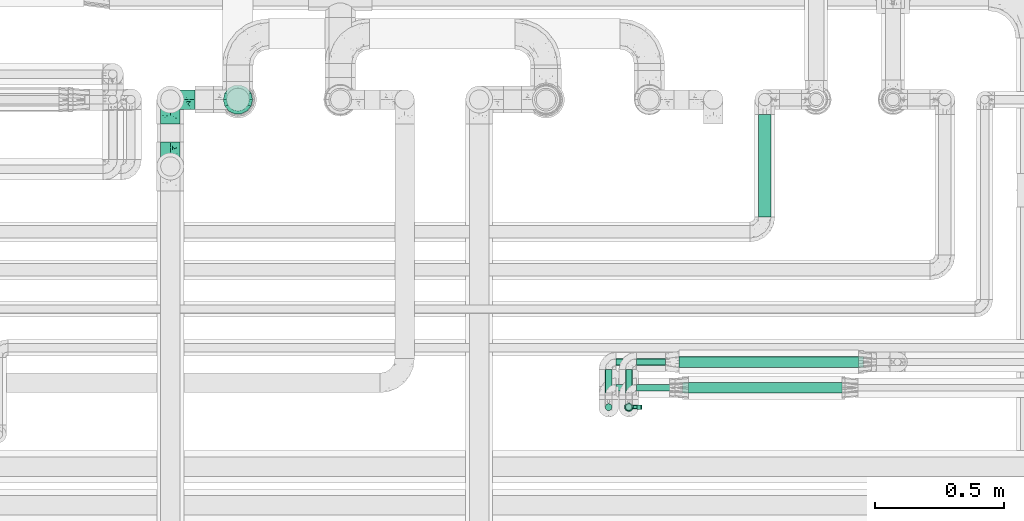
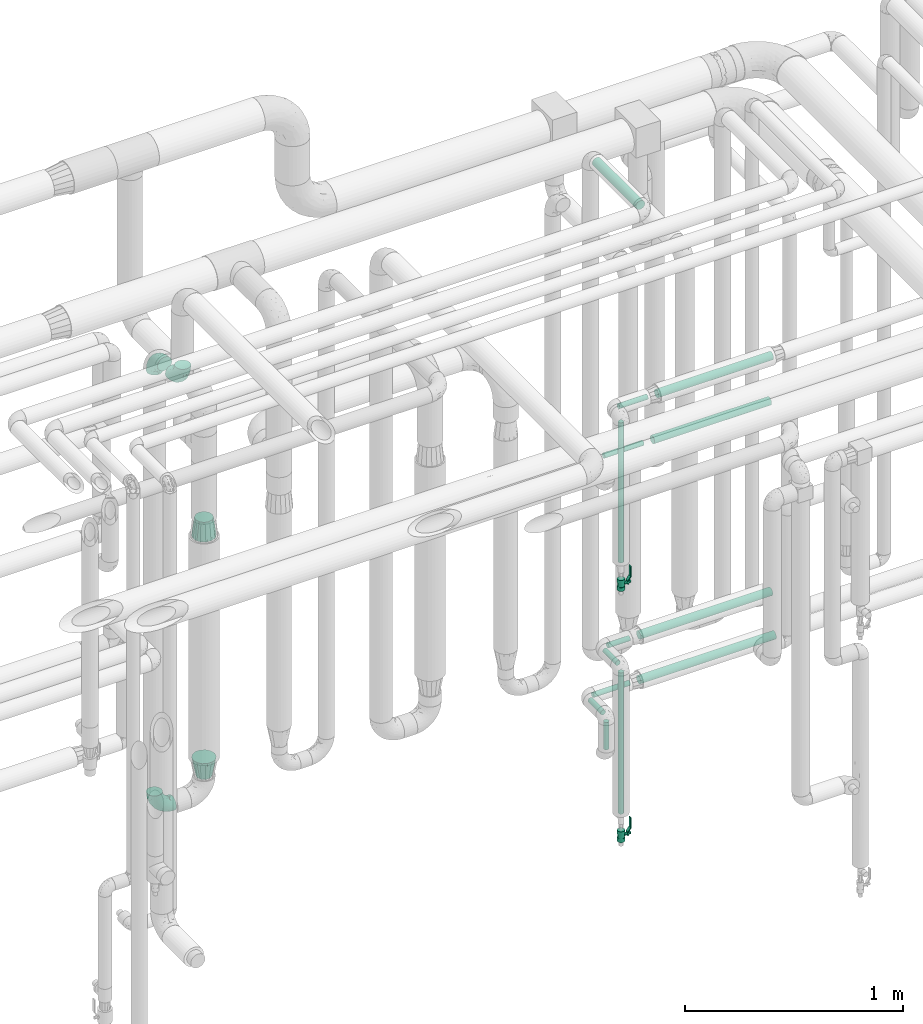
# One storey, part 709 of 827: 14 flow segments, 5 flow fittings, 2 flow controllers.
"""IFC2X3 building model written with IfcOpenShell, lengths in millimetres."""

from ifc_helpers import new_model, entity, si_unit, converted_unit, derived_unit, direction, frame, origin, origin_2d_with_axis, place, context, subcontext, project, spatial, polyline, circle, outline, extrude, faceted_brep, source, transform, mapped, material, material_list, type_object, type_shapes, element, save


model = new_model("IFC2X3")

# Units and contexts
model_context = context("Model", 3, precision=0.01, world=origin(), true_north=direction((6.12303176911189e-17, 1.0)))
body_context = subcontext(model_context, "Body", "Model", "MODEL_VIEW")
ifc_project = project(units=[si_unit("LENGTHUNIT", "METRE", prefix="MILLI"), si_unit("AREAUNIT", "SQUARE_METRE"), si_unit("VOLUMEUNIT", "CUBIC_METRE"), converted_unit("PLANEANGLEUNIT", "DEGREE", entity("IfcRatioMeasure", 0.0174532925199433), si_unit("PLANEANGLEUNIT", "RADIAN"), dimensions=[0, 0, 0, 0, 0, 0, 0]), si_unit("MASSUNIT", "GRAM", prefix="KILO"), derived_unit("MASSDENSITYUNIT", [(si_unit("MASSUNIT", "GRAM", prefix="KILO"), 1), (si_unit("LENGTHUNIT", "METRE"), -3)]), derived_unit("MOMENTOFINERTIAUNIT", [(si_unit("LENGTHUNIT", "METRE"), 4)]), si_unit("TIMEUNIT", "SECOND"), si_unit("FREQUENCYUNIT", "HERTZ"), si_unit("THERMODYNAMICTEMPERATUREUNIT", "DEGREE_CELSIUS"), derived_unit("THERMALTRANSMITTANCEUNIT", [(si_unit("MASSUNIT", "GRAM", prefix="KILO"), 1), (si_unit("THERMODYNAMICTEMPERATUREUNIT", "KELVIN"), -1), (si_unit("TIMEUNIT", "SECOND"), -3)]), derived_unit("VOLUMETRICFLOWRATEUNIT", [(si_unit("LENGTHUNIT", "METRE"), 3), (si_unit("TIMEUNIT", "SECOND"), -1)]), derived_unit("MASSFLOWRATEUNIT", [(si_unit("MASSUNIT", "GRAM", prefix="KILO"), 1), (si_unit("TIMEUNIT", "SECOND"), -1)]), derived_unit("ROTATIONALFREQUENCYUNIT", [(si_unit("TIMEUNIT", "SECOND"), -1)]), si_unit("ELECTRICCURRENTUNIT", "AMPERE"), si_unit("ELECTRICVOLTAGEUNIT", "VOLT"), si_unit("POWERUNIT", "WATT"), si_unit("FORCEUNIT", "NEWTON", prefix="KILO"), si_unit("ILLUMINANCEUNIT", "LUX"), si_unit("LUMINOUSFLUXUNIT", "LUMEN"), si_unit("LUMINOUSINTENSITYUNIT", "CANDELA"), derived_unit("USERDEFINED", [(si_unit("MASSUNIT", "GRAM", prefix="KILO"), -1), (si_unit("LENGTHUNIT", "METRE"), -2), (si_unit("TIMEUNIT", "SECOND"), 3), (si_unit("LUMINOUSFLUXUNIT", "LUMEN"), 1)]), derived_unit("LINEARVELOCITYUNIT", [(si_unit("LENGTHUNIT", "METRE"), 1), (si_unit("TIMEUNIT", "SECOND"), -1)]), si_unit("PRESSUREUNIT", "PASCAL"), derived_unit("USERDEFINED", [(si_unit("LENGTHUNIT", "METRE"), -2), (si_unit("MASSUNIT", "GRAM", prefix="KILO"), 1), (si_unit("TIMEUNIT", "SECOND"), -2)]), derived_unit("LINEARFORCEUNIT", [(si_unit("MASSUNIT", "GRAM", prefix="KILO"), 1), (si_unit("LENGTHUNIT", "METRE"), 1), (si_unit("TIMEUNIT", "SECOND"), -2), (si_unit("LENGTHUNIT", "METRE"), -1)]), derived_unit("PLANARFORCEUNIT", [(si_unit("MASSUNIT", "GRAM", prefix="KILO"), 1), (si_unit("LENGTHUNIT", "METRE"), 1), (si_unit("TIMEUNIT", "SECOND"), -2), (si_unit("LENGTHUNIT", "METRE"), -2)])], contexts=[model_context])

# Site, building, storey
site_placement = place(None, origin())
site = spatial("IfcSite", under=ifc_project, at=site_placement, CompositionType="ELEMENT")
building_placement = place(site_placement, origin())
building = spatial("IfcBuilding", under=site, at=building_placement, CompositionType="ELEMENT")
storey_placement = place(building_placement, frame((0.0, 0.0, 28200.0)))
storey = spatial("IfcBuildingStorey", under=building, at=storey_placement, Name="08", CompositionType="ELEMENT", Elevation=28200.0)

# Flow segments
pipe_segment_type = type_object("IfcPipeSegmentType", PredefinedType="NOTDEFINED")
flow_segment_1_placement = place(storey_placement, frame((58598.69, 16364.84, 2635.0)))
element("IfcFlowSegment", 1, at=flow_segment_1_placement, inside=storey, type_object=pipe_segment_type, context=body_context, shape_type="SweptSolid", body=[
    extrude(circle(Radius=13.4, at=origin_2d_with_axis()), frame((0.0, 15.0, 15.0), z_axis=(1.0, 0.0, 0.0), x_axis=(0.0, 1.0, 0.0)), (0.0, 0.0, 1.0), 151.411857725938),
])
flow_segment_2_placement = place(storey_placement, frame((58554.6, 16289.84, 1836.7)))
element("IfcFlowSegment", 2, at=flow_segment_2_placement, inside=storey, type_object=pipe_segment_type, context=body_context, shape_type="SweptSolid", body=[
    extrude(circle(Radius=13.4, at=origin_2d_with_axis()), frame((15.0, 15.0, 0.0)), (0.0, 0.0, 1.0), 784.200205145647),
])
flow_segment_3_placement = place(storey_placement, frame((58554.6, 16333.95, 1235.0)))
element("IfcFlowSegment", 3, at=flow_segment_3_placement, inside=storey, type_object=pipe_segment_type, context=body_context, shape_type="SweptSolid", body=[
    extrude(circle(Radius=13.4, at=origin_2d_with_axis()), frame((15.0, 0.0, 15.0), z_axis=(0.0, 1.0, 0.0), x_axis=(1.0, 0.0, 0.0)), (0.0, 0.0, 1.0), 116.174999999997),
])
flow_segment_4_placement = place(storey_placement, frame((58554.6, 16289.85, 429.0)))
element("IfcFlowSegment", 4, at=flow_segment_4_placement, inside=storey, type_object=pipe_segment_type, context=body_context, shape_type="SweptSolid", body=[
    extrude(circle(Radius=13.4, at=origin_2d_with_axis()), frame((15.0, 15.0, 0.0)), (0.0, 0.0, 1.0), 791.899999709113),
])
flow_segment_5_placement = place(storey_placement, frame((58598.69, 16464.23, 1235.0)))
element("IfcFlowSegment", 5, at=flow_segment_5_placement, inside=storey, type_object=pipe_segment_type, context=body_context, shape_type="SweptSolid", body=[
    extrude(circle(Radius=13.4, at=origin_2d_with_axis()), frame((0.0, 15.0, 15.0), z_axis=(1.0, 0.0, 0.0), x_axis=(0.0, -1.0, 0.0)), (0.0, 0.0, 1.0), 114.325940465235),
])
flow_segment_6_placement = place(storey_placement, frame((58476.2, 16333.49, 985.0)))
element("IfcFlowSegment", 6, at=flow_segment_6_placement, inside=storey, type_object=pipe_segment_type, context=body_context, shape_type="SweptSolid", body=[
    extrude(circle(Radius=13.4, at=origin_2d_with_axis()), frame((15.0, 0.0, 15.0), z_axis=(0.0, 1.0, 0.0), x_axis=(1.0, 0.0, 0.0)), (0.0, 0.0, 1.0), 116.636658406557),
])
flow_segment_7_placement = place(storey_placement, frame((58476.2, 16289.39, 817.55)))
element("IfcFlowSegment", 7, at=flow_segment_7_placement, inside=storey, type_object=pipe_segment_type, context=body_context, shape_type="SweptSolid", body=[
    extrude(circle(Radius=13.4, at=origin_2d_with_axis()), frame((15.0, 15.0, 0.0)), (0.0, 0.0, 1.0), 153.34576210052),
])
flow_segment_8_placement = place(storey_placement, frame((58520.29, 16464.19, 985.0)))
element("IfcFlowSegment", 8, at=flow_segment_8_placement, inside=storey, type_object=pipe_segment_type, context=body_context, shape_type="SweptSolid", body=[
    extrude(circle(Radius=13.4, at=origin_2d_with_axis()), frame((0.0, 15.03, 15.0), z_axis=(0.999999985627903, -0.000169541125269406, 0.0), x_axis=(-0.000169541125269406, -0.999999985627903, 0.0)), (0.0, 0.0, 1.0), 192.725953702304),
])
flow_segment_9_placement = place(storey_placement, frame((59072.54, 17042.69, 3174.4)))
element("IfcFlowSegment", 9, at=flow_segment_9_placement, inside=storey, type_object=pipe_segment_type, context=body_context, shape_type="SweptSolid", body=[
    extrude(circle(Radius=24.0, at=origin_2d_with_axis()), frame((25.6, 0.0, 25.6), z_axis=(0.0, 1.0, 0.0), x_axis=(-1.0, 0.0, 0.0)), (0.0, 0.0, 1.0), 400.304686356029),
])
flow_segment_10_placement = place(storey_placement, frame((58764.02, 16456.48, 977.25)))
element("IfcFlowSegment", 10, at=flow_segment_10_placement, inside=storey, type_object=pipe_segment_type, context=body_context, shape_type="SweptSolid", body=[
    extrude(circle(Radius=21.15, at=origin_2d_with_axis()), frame((0.0, 22.75, 22.75), z_axis=(1.0, 0.0, 6.7602214637812e-06), x_axis=(0.0, 1.0, 0.0)), (0.0, 0.0, 1.0), 717.619049674226),
])
flow_segment_11_placement = place(storey_placement, frame((58764.02, 16456.91, 1227.25)))
element("IfcFlowSegment", 11, at=flow_segment_11_placement, inside=storey, type_object=pipe_segment_type, context=body_context, shape_type="SweptSolid", body=[
    extrude(circle(Radius=21.15, at=origin_2d_with_axis()), frame((0.0, 22.75, 22.75), z_axis=(1.0, 0.0, 0.0), x_axis=(0.0, -1.0, 0.0)), (0.0, 0.0, 1.0), 698.842962557812),
])
flow_segment_12_placement = place(storey_placement, frame((58778.82, 16357.09, 2377.25)))
element("IfcFlowSegment", 12, at=flow_segment_12_placement, inside=storey, type_object=pipe_segment_type, context=body_context, shape_type="SweptSolid", body=[
    extrude(circle(Radius=21.15, at=origin_2d_with_axis()), frame((0.0, 22.75, 22.75), z_axis=(1.0, 0.0, 0.0), x_axis=(0.0, 1.0, 0.0)), (0.0, 0.0, 1.0), 620.000000000006),
])
flow_segment_13_placement = place(storey_placement, frame((58801.1, 16357.09, 2627.25)))
element("IfcFlowSegment", 13, at=flow_segment_13_placement, inside=storey, type_object=pipe_segment_type, context=body_context, shape_type="SweptSolid", body=[
    extrude(circle(Radius=21.15, at=origin_2d_with_axis()), frame((0.0, 22.75, 22.75), z_axis=(1.0, 0.0, 0.0), x_axis=(0.0, -1.0, 0.0)), (0.0, 0.0, 1.0), 608.330451835312),
])
flow_segment_14_placement = place(storey_placement, frame((58520.29, 16364.84, 2385.0)))
element("IfcFlowSegment", 14, at=flow_segment_14_placement, inside=storey, type_object=pipe_segment_type, context=body_context, shape_type="SweptSolid", body=[
    extrude(circle(Radius=13.4, at=origin_2d_with_axis()), frame((0.0, 15.0, 15.0), z_axis=(1.0, 0.0, 0.0), x_axis=(0.0, 1.0, 0.0)), (0.0, 0.0, 1.0), 207.529319801584),
])

# Flow controllers
ifc_material = material()
ifc_material_list = material_list([ifc_material, ifc_material, ifc_material, ifc_material, ifc_material])
valve_type = type_object("IfcValveType", PredefinedType="NOTDEFINED", material=ifc_material_list)
shared_shape_1 = source(origin(), body_context, "Body", "SweptSolid", [
    extrude(circle(Radius=17.5, at=origin_2d_with_axis()), frame((-30.5, 0.0, 0.0), z_axis=(1.0, 0.0, 0.0), x_axis=(0.0, 1.0, 0.0)), (0.0, 0.0, 1.0), 20.3333333333333),
    extrude(circle(Radius=16.0, at=origin_2d_with_axis()), frame((-10.17, 0.0, 0.0), z_axis=(1.0, 0.0, 0.0), x_axis=(0.0, 1.0, 0.0)), (0.0, 0.0, 1.0), 20.3333333333333),
    extrude(circle(Radius=17.5, at=origin_2d_with_axis()), frame((10.17, 0.0, 0.0), z_axis=(1.0, 0.0, 0.0), x_axis=(0.0, 1.0, 0.0)), (0.0, 0.0, 1.0), 20.3333333333333),
    extrude(outline(polyline([(-38.75, -5.0), (-38.75, -10.0), (-17.92, -10.0), (2.08, 5.0), (56.25, 5.0), (56.25, 10.0), (0.42, 10.0), (-19.58, -5.0), (-38.75, -5.0)])), frame((28.75, -8.75, 41.5), z_axis=(0.0, -1.0, 0.0), x_axis=(1.0, 0.0, 0.0)), (0.0, 0.0, -1.0), 17.5),
    extrude(circle(Radius=8.0, at=origin_2d_with_axis()), origin(), (0.0, 0.0, 1.0), 49.0),
])
type_shapes(valve_type, [shared_shape_1])
for number, where, z_axis, x_axis in (
    (15, (58569.59, 16304.84, 1710.2), (1.0, 0.0, 0.0), (0.0, 0.0, 1.0)),
    (16, (58569.59, 16304.85, 302.5), (1.0, 0.0, 0.0), (0.0, 0.0, 1.0)),
):
    element("IfcFlowController", number, at=place(storey_placement, frame(where, z_axis=z_axis, x_axis=x_axis)), inside=storey, type_object=valve_type, material=ifc_material, context=body_context, shape_type="MappedRepresentation", body=[
        mapped(shared_shape_1, transform((0.0, 0.0, 0.0), scale=1.0)),
    ])

# Flow fittings
pipe_fitting_type_1 = type_object("IfcPipeFittingType", Name="ADSK_1", PredefinedType="NOTDEFINED", material=ifc_material)
shared_shape_2 = source(origin(), body_context, "Body", "Brep", [
    faceted_brep([(-95.0, 19.02, -32.95), (-95.0, 9.85, -36.75), (-95.0, 0.0, -38.05), (-95.0, -9.85, -36.75), (-95.0, -19.03, -32.95), (-95.0, -26.91, -26.91), (-95.0, -32.95, -19.03), (-95.0, -36.75, -9.85), (-95.0, -38.05, 0.0), (-95.0, -36.75, 9.85), (-95.0, -32.95, 19.02), (-95.0, -26.91, 26.91), (-95.0, -19.03, 32.95), (-95.0, -9.85, 36.75), (-95.0, 0.0, 38.05), (-95.0, 9.85, 36.75), (-95.0, 19.02, 32.95), (-95.0, 26.91, 26.91), (-95.0, 32.95, 19.02), (-95.0, 36.75, 9.85), (-95.0, 38.05, 0.0), (-95.0, 36.75, -9.85), (-95.0, 32.95, -19.03), (-95.0, 26.91, -26.91), (0.0, 95.0, -38.05), (-9.85, 95.0, -36.75), (-19.02, 95.0, -32.95), (-26.91, 95.0, -26.91), (-32.95, 95.0, -19.03), (-36.75, 95.0, -9.85), (-38.05, 95.0, 0.0), (-36.75, 95.0, 9.85), (-32.95, 95.0, 19.02), (-26.91, 95.0, 26.91), (-19.02, 95.0, 32.95), (-9.85, 95.0, 36.75), (0.0, 95.0, 38.05), (9.85, 95.0, 36.75), (19.03, 95.0, 32.95), (26.91, 95.0, 26.91), (32.95, 95.0, 19.02), (36.75, 95.0, 9.85), (38.05, 95.0, 0.0), (36.75, 95.0, -9.85), (32.95, 95.0, -19.03), (26.91, 95.0, -26.91), (19.03, 95.0, -32.95), (9.85, 95.0, -36.75), (-7.99, -4.96, 6.3), (-0.92, 0.92, 0.0), (4.62, 8.1, 8.01), (-76.19, -35.57, 0.0), (-64.32, -32.32, 12.43), (20.51, 62.45, 28.68), (-60.56, -33.52, 0.0), (-70.4, -13.47, 34.42), (-39.61, -5.88, 32.32), (-49.6, 2.07, 37.1), (-70.34, -28.81, 21.71), (14.64, 40.81, 26.5), (5.88, 39.61, 32.32), (3.59, 20.77, 25.31), (-40.45, 68.06, 16.75), (-62.45, -20.51, 28.68), (-44.52, -26.87, 0.0), (-28.47, -20.22, 0.0), (-26.43, -17.83, 8.75), (-76.1, 39.63, 10.76), (-72.74, 37.58, 18.19), (-60.35, 46.18, 14.61), (-13.4, 13.4, 32.12), (-20.77, -3.59, 25.31), (-14.66, 81.47, 35.56), (-6.22, 71.26, 37.92), (-57.5, 42.48, 22.79), (-15.0, 34.74, 37.7), (-27.1, 12.08, 36.05), (-9.2, 28.81, 35.63), (-79.98, 23.7, 30.95), (-73.68, -4.3, 37.48), (-30.74, 21.67, 37.97), (-62.36, 47.59, 6.79), (-72.71, 32.83, 24.69), (-67.42, 7.02, 37.95), (-32.13, 75.27, 24.51), (-43.46, 51.47, 26.26), (-24.98, 73.15, 31.29), (20.59, 41.28, 19.85), (7.79, 16.09, 15.86), (-73.21, 42.39, 0.0), (-54.73, 54.73, 0.0), (-73.44, 15.79, 35.79), (-5.94, 4.32, 20.43), (28.81, 70.34, 21.71), (32.32, 64.32, 12.43), (-53.59, 26.2, 35.09), (-52.02, 19.31, 37.21), (21.38, 33.53, 10.34), (26.87, 44.52, 0.0), (-48.28, 12.14, 38.05), (4.3, 73.68, 37.48), (-44.08, -25.52, 12.79), (-41.28, -20.59, 19.85), (35.57, 76.19, 0.0), (-47.26, 54.3, 20.18), (-47.4, 61.99, 8.58), (-42.39, 73.21, 0.0), (-39.67, 78.86, 7.21), (-45.69, 36.84, 33.11), (-32.83, 50.13, 33.35), (13.47, 70.4, 34.42), (-18.25, 63.73, 36.07), (-40.63, -13.75, 27.22), (-16.63, 46.37, 37.95), (-53.47, 38.79, 28.59), (-26.07, 48.54, 36.15), (-34.51, 34.51, 36.86), (-2.07, 49.6, 37.1), (-22.79, -10.49, 19.23), (-61.73, 28.67, 31.87), (9.65, 14.7, 0.0), (20.22, 28.47, 0.0), (33.52, 60.56, 0.0), (-11.42, -5.44, 13.25), (-14.7, -9.65, 0.0), (-81.47, 14.66, -35.56), (-62.45, -20.51, -28.68), (-71.26, 6.22, -37.92), (-75.27, 32.13, -24.51), (-73.15, 24.98, -31.29), (13.47, 70.4, -34.42), (5.88, 39.61, -32.32), (-2.07, 49.6, -37.1), (-78.86, 39.67, -7.21), (-70.4, -13.47, -34.42), (-39.61, -5.88, -32.32), (-61.99, 47.4, -8.58), (32.32, 64.32, -12.43), (28.81, 70.34, -21.71), (-63.73, 18.25, -36.07), (-50.13, 32.83, -33.35), (4.3, 73.68, -37.48), (-7.02, 67.42, -37.95), (-39.63, 76.1, -10.76), (-46.18, 60.35, -14.61), (-47.59, 62.36, -6.79), (-64.32, -32.32, -12.43), (-26.2, 53.59, -35.09), (-15.79, 73.44, -35.79), (-19.31, 52.02, -37.21), (-37.58, 72.74, -18.19), (-70.34, -28.81, -21.71), (-42.48, 57.5, -22.79), (-38.79, 53.47, -28.59), (-51.47, 43.46, -26.26), (-32.83, 72.71, -24.69), (-46.37, 16.63, -37.95), (-73.68, -4.3, -37.48), (-41.28, -20.59, -19.85), (-44.08, -25.52, -12.79), (13.75, 40.63, -27.22), (20.51, 62.45, -28.68), (-68.06, 40.45, -16.75), (-54.3, 47.26, -20.18), (-12.14, 48.28, -38.05), (-21.67, 30.74, -37.97), (-36.84, 45.69, -33.11), (-11.42, -5.44, -13.25), (7.79, 16.09, -15.86), (4.62, 8.1, -8.01), (-23.7, 79.98, -30.95), (-26.43, -17.83, -8.75), (-7.99, -4.96, -6.3), (-40.81, -14.64, -26.5), (-20.77, -3.59, -25.31), (-34.74, 15.0, -37.7), (-12.08, 27.1, -36.05), (-28.81, 9.2, -35.63), (-22.79, -10.49, -19.23), (21.38, 33.53, -10.34), (20.59, 41.28, -19.85), (-48.54, 26.07, -36.15), (-49.6, 2.07, -37.1), (-13.4, 13.4, -32.12), (3.59, 20.77, -25.31), (-28.67, 61.73, -31.87), (-34.51, 34.51, -36.86), (-5.94, 4.32, -20.43)], [[[0, 1, 2, 3, 4, 5, 6, 7, 8, 9, 10, 11, 12, 13, 14, 15, 16, 17, 18, 19, 20, 21, 22, 23]], [[24, 25, 26, 27, 28, 29, 30, 31, 32, 33, 34, 35, 36, 37, 38, 39, 40, 41, 42, 43, 44, 45, 46, 47]], [[48, 49, 50]], [[51, 52, 9]], [[53, 39, 38]], [[9, 52, 10]], [[54, 52, 51]], [[55, 56, 57]], [[11, 10, 58]], [[59, 60, 61]], [[32, 31, 62]], [[63, 12, 11]], [[63, 55, 12]], [[64, 65, 66]], [[67, 68, 69]], [[70, 56, 71]], [[35, 72, 73]], [[69, 68, 74]], [[75, 76, 77]], [[16, 78, 17]], [[13, 79, 14]], [[76, 75, 80]], [[67, 69, 81]], [[18, 17, 82]], [[14, 79, 83]], [[20, 19, 67]], [[84, 85, 86]], [[87, 61, 88]], [[89, 81, 90]], [[18, 82, 68]], [[15, 91, 16]], [[14, 83, 15]], [[71, 92, 61]], [[17, 78, 82]], [[93, 87, 94]], [[95, 91, 96]], [[97, 98, 94]], [[86, 72, 34]], [[96, 99, 80]], [[37, 36, 100]], [[40, 39, 93]], [[40, 94, 41]], [[64, 66, 101]], [[93, 94, 40]], [[58, 102, 63]], [[94, 103, 41]], [[94, 87, 97]], [[104, 69, 74]], [[34, 33, 86]], [[105, 69, 104]], [[52, 58, 10]], [[106, 107, 30]], [[108, 109, 85]], [[105, 106, 90]], [[53, 110, 60]], [[86, 111, 72]], [[86, 109, 111]], [[33, 84, 86]], [[12, 55, 13]], [[112, 56, 63]], [[110, 38, 37]], [[34, 72, 35]], [[36, 35, 73]], [[111, 113, 73]], [[105, 107, 106]], [[110, 53, 38]], [[74, 114, 85]], [[91, 15, 83]], [[105, 90, 81]], [[107, 62, 31]], [[33, 32, 84]], [[115, 109, 116]], [[111, 115, 113]], [[100, 73, 117]], [[56, 55, 63]], [[79, 55, 57]], [[102, 118, 112]], [[56, 70, 76]], [[100, 110, 37]], [[117, 77, 60]], [[117, 60, 110]], [[60, 70, 61]], [[58, 52, 101]], [[63, 11, 58]], [[39, 53, 93]], [[87, 93, 53]], [[96, 91, 83]], [[78, 91, 119]], [[32, 62, 84]], [[84, 62, 104]], [[86, 85, 109]], [[85, 114, 108]], [[80, 113, 116]], [[117, 73, 113]], [[80, 116, 96]], [[80, 57, 76]], [[71, 112, 118]], [[61, 87, 59]], [[62, 107, 105]], [[97, 120, 121]], [[70, 71, 61]], [[71, 118, 92]], [[73, 100, 36]], [[110, 100, 117]], [[55, 79, 13]], [[83, 79, 57]], [[96, 83, 99]], [[116, 108, 95]], [[50, 97, 88]], [[97, 87, 88]], [[50, 49, 120]], [[122, 94, 98]], [[89, 20, 67]], [[105, 81, 69]], [[89, 67, 81]], [[68, 19, 18]], [[68, 67, 19]], [[74, 68, 82]], [[114, 82, 119]], [[74, 85, 104]], [[82, 114, 74]], [[114, 119, 108]], [[95, 108, 119]], [[116, 109, 108]], [[123, 48, 50]], [[97, 50, 120]], [[123, 50, 88]], [[91, 95, 119]], [[116, 95, 96]], [[84, 104, 85]], [[104, 62, 105]], [[83, 57, 99]], [[57, 80, 99]], [[66, 48, 123]], [[66, 124, 48]], [[118, 66, 123]], [[124, 66, 65]], [[66, 118, 101]], [[54, 64, 52]], [[124, 49, 48]], [[30, 107, 31]], [[91, 78, 16]], [[82, 78, 119]], [[56, 76, 57]], [[77, 76, 70]], [[60, 77, 70]], [[77, 117, 75]], [[117, 113, 75]], [[113, 80, 75]], [[9, 8, 51]], [[103, 94, 122]], [[103, 42, 41]], [[73, 72, 111]], [[113, 115, 116]], [[111, 109, 115]], [[102, 112, 63]], [[71, 56, 112]], [[118, 102, 101]], [[92, 123, 88]], [[123, 92, 118]], [[61, 92, 88]], [[87, 53, 59]], [[60, 59, 53]], [[97, 121, 98]], [[58, 101, 102]], [[64, 101, 52]], [[125, 1, 0]], [[126, 5, 4]], [[2, 1, 127]], [[1, 125, 127]], [[128, 129, 23]], [[130, 131, 132]], [[89, 133, 20]], [[126, 134, 135]], [[136, 89, 90]], [[137, 138, 44]], [[139, 129, 140]], [[24, 141, 142]], [[143, 144, 145]], [[125, 129, 139]], [[6, 146, 7]], [[147, 148, 149]], [[146, 51, 7]], [[143, 150, 144]], [[146, 6, 151]], [[152, 153, 154]], [[126, 4, 134]], [[0, 23, 129]], [[28, 155, 150]], [[43, 42, 103]], [[54, 146, 64]], [[139, 156, 127]], [[157, 3, 2]], [[151, 158, 159]], [[160, 131, 161]], [[22, 21, 162]], [[136, 144, 163]], [[149, 164, 165]], [[24, 142, 25]], [[166, 140, 154]], [[154, 129, 128]], [[143, 30, 29]], [[167, 168, 169]], [[155, 28, 27]], [[26, 170, 27]], [[171, 167, 172]], [[26, 25, 148]], [[27, 170, 155]], [[173, 135, 174]], [[144, 150, 152]], [[175, 176, 177]], [[24, 47, 141]], [[45, 161, 46]], [[148, 25, 142]], [[176, 175, 165]], [[64, 159, 171]], [[138, 45, 44]], [[130, 46, 161]], [[137, 44, 43]], [[178, 159, 158]], [[137, 103, 122]], [[163, 144, 152]], [[136, 133, 89]], [[103, 137, 43]], [[6, 5, 151]], [[178, 158, 173]], [[134, 4, 3]], [[178, 173, 174]], [[137, 98, 179]], [[145, 90, 106]], [[138, 180, 161]], [[46, 130, 47]], [[136, 90, 145]], [[133, 162, 21]], [[23, 22, 128]], [[139, 140, 181]], [[139, 181, 156]], [[157, 127, 182]], [[157, 134, 3]], [[182, 177, 135]], [[182, 135, 134]], [[135, 183, 174]], [[131, 130, 161]], [[141, 130, 132]], [[160, 180, 184]], [[131, 183, 176]], [[5, 126, 151]], [[158, 151, 126]], [[180, 138, 137]], [[161, 45, 138]], [[149, 148, 142]], [[170, 148, 185]], [[22, 162, 128]], [[128, 162, 163]], [[129, 154, 140]], [[154, 153, 166]], [[165, 156, 186]], [[182, 127, 156]], [[165, 186, 149]], [[165, 132, 176]], [[131, 184, 183]], [[187, 167, 178]], [[184, 168, 187]], [[167, 169, 172]], [[184, 180, 168]], [[174, 183, 184]], [[127, 157, 2]], [[134, 157, 182]], [[130, 141, 47]], [[142, 141, 132]], [[149, 142, 164]], [[186, 166, 147]], [[180, 179, 168]], [[169, 179, 120]], [[137, 179, 180]], [[179, 121, 120]], [[106, 30, 143]], [[136, 145, 144]], [[106, 143, 145]], [[150, 29, 28]], [[150, 143, 29]], [[152, 150, 155]], [[153, 155, 185]], [[152, 154, 163]], [[155, 153, 152]], [[153, 185, 166]], [[147, 166, 185]], [[186, 140, 166]], [[169, 120, 49]], [[169, 49, 172]], [[179, 169, 168]], [[148, 147, 185]], [[186, 147, 149]], [[128, 163, 154]], [[163, 162, 136]], [[142, 132, 164]], [[132, 165, 164]], [[171, 124, 65]], [[124, 171, 172]], [[64, 146, 159]], [[171, 159, 178]], [[171, 65, 64]], [[172, 49, 124]], [[162, 133, 136]], [[20, 133, 21]], [[148, 170, 26]], [[155, 170, 185]], [[131, 176, 132]], [[177, 176, 183]], [[135, 177, 183]], [[177, 182, 175]], [[182, 156, 175]], [[156, 165, 175]], [[51, 146, 54]], [[51, 8, 7]], [[129, 125, 0]], [[127, 125, 139]], [[140, 186, 181]], [[156, 181, 186]], [[158, 126, 173]], [[135, 173, 126]], [[187, 178, 174]], [[171, 178, 167]], [[184, 187, 174]], [[167, 187, 168]], [[180, 160, 161]], [[184, 131, 160]], [[98, 137, 122]], [[98, 121, 179]], [[151, 159, 146]]]),
])
type_shapes(pipe_fitting_type_1, [shared_shape_2])
for number, where, z_axis, x_axis, name in (
    (17, (56787.39, 17500.0, 352.5), (0.0, 1.0, 0.0), (-1.0, 0.0, 0.0), "ADSK_1"),
    (18, (56787.39, 17240.0, 2900.0), (1.0, 0.0, 0.0), (0.0, 0.0, -1.0), "ADSK_1"),
    (19, (56787.39, 17500.0, 2900.0), (1.0, 0.0, 0.0), (0.0, 0.0, 1.0), "ADSK_1"),
):
    element("IfcFlowFitting", number, at=place(storey_placement, frame(where, z_axis=z_axis, x_axis=x_axis)), inside=storey, type_object=pipe_fitting_type_1, material=ifc_material, Name=name, ObjectType="ADSK_1", context=body_context, shape_type="MappedRepresentation", body=[
        mapped(shared_shape_2, transform((0.0, 0.0, 0.0), scale=1.0)),
    ])
pipe_fitting_type_2 = type_object("IfcPipeFittingType", Name="ADSK_1", PredefinedType="NOTDEFINED", material=ifc_material)
shared_shape_3 = source(origin(), body_context, "Body", "Brep", [
    faceted_brep([(102.0, -30.36, 30.36), (102.0, -38.49, 22.23), (102.0, -41.47, 11.11), (102.0, -44.45, 0.0), (102.0, -41.47, -11.11), (102.0, -38.49, -22.22), (102.0, -30.36, -30.36), (102.0, -22.23, -38.49), (102.0, -11.11, -41.47), (102.0, 0.0, -44.45), (102.0, 11.11, -41.47), (102.0, 22.22, -38.49), (102.0, 30.36, -30.36), (102.0, 38.49, -22.22), (102.0, 41.47, -11.11), (102.0, 44.45, 0.0), (102.0, 41.47, 11.11), (102.0, 38.49, 22.23), (102.0, 30.36, 30.36), (102.0, 22.22, 38.49), (102.0, 11.11, 41.47), (102.0, 0.0, 44.45), (102.0, -11.11, 41.47), (102.0, -22.23, 38.49), (0.0, 24.17, 50.2), (0.0, 35.63, 44.68), (0.0, 43.56, 34.74), (0.0, 51.49, 24.8), (0.0, 54.32, 12.4), (0.0, 57.15, 0.0), (0.0, 54.32, -12.4), (0.0, 51.49, -24.8), (0.0, 43.56, -34.74), (0.0, 35.63, -44.68), (0.0, 24.17, -50.2), (0.0, 12.72, -55.72), (0.0, 0.0, -55.72), (0.0, -12.72, -55.72), (0.0, -24.17, -50.2), (0.0, -35.63, -44.68), (0.0, -43.56, -34.74), (0.0, -51.49, -24.8), (0.0, -54.32, -12.4), (0.0, -57.15, 0.0), (0.0, -54.32, 12.4), (0.0, -51.49, 24.8), (0.0, -43.56, 34.74), (0.0, -35.63, 44.68), (0.0, -24.17, 50.2), (0.0, -12.72, 55.72), (0.0, 0.0, 55.72), (0.0, 12.72, 55.72)], [[[0, 1, 2, 3, 4, 5, 6, 7, 8, 9, 10, 11, 12, 13, 14, 15, 16, 17, 18, 19, 20, 21, 22, 23]], [[24, 25, 26, 27, 28, 29, 30, 31, 32, 33, 34, 35, 36, 37, 38, 39, 40, 41, 42, 43, 44, 45, 46, 47, 48, 49, 50, 51]], [[14, 31, 30]], [[42, 3, 43]], [[32, 31, 13]], [[13, 31, 14]], [[34, 10, 35]], [[3, 42, 4]], [[12, 11, 33]], [[9, 37, 36, 35]], [[7, 39, 38]], [[39, 7, 6]], [[38, 8, 7]], [[34, 33, 11]], [[10, 9, 35]], [[40, 5, 41]], [[12, 33, 32]], [[15, 30, 29]], [[38, 37, 8]], [[15, 14, 30]], [[41, 5, 4]], [[5, 40, 6]], [[13, 12, 32]], [[10, 34, 11]], [[37, 9, 8]], [[40, 39, 6]], [[42, 41, 4]], [[2, 45, 44]], [[28, 15, 29]], [[46, 45, 1]], [[1, 45, 2]], [[48, 22, 49]], [[15, 28, 16]], [[0, 23, 47]], [[21, 51, 50, 49]], [[19, 25, 24]], [[25, 19, 18]], [[24, 20, 19]], [[48, 47, 23]], [[22, 21, 49]], [[26, 17, 27]], [[0, 47, 46]], [[3, 44, 43]], [[24, 51, 20]], [[3, 2, 44]], [[27, 17, 16]], [[17, 26, 18]], [[1, 0, 46]], [[22, 48, 23]], [[51, 21, 20]], [[26, 25, 18]], [[28, 27, 16]]]),
])
type_shapes(pipe_fitting_type_2, [shared_shape_3])
flow_fitting_1_placement = place(storey_placement, frame((57050.07, 17500.0, 1790.74), z_axis=(0.0, 1.0, 0.0), x_axis=(0.0, 0.0, 1.0)))
element("IfcFlowFitting", 20, at=flow_fitting_1_placement, inside=storey, type_object=pipe_fitting_type_2, material=ifc_material, Name="ADSK_1", ObjectType="ADSK_1", context=body_context, shape_type="MappedRepresentation", body=[
    mapped(shared_shape_3, transform((0.0, 0.0, 0.0), scale=1.0)),
])
pipe_fitting_type_3 = type_object("IfcPipeFittingType", Name="ADSK_1", PredefinedType="NOTDEFINED", material=ifc_material)
shared_shape_4 = source(origin(), body_context, "Body", "Brep", [
    faceted_brep([(102.0, -57.15, 0.0), (102.0, -54.32, -12.4), (102.0, -51.49, -24.8), (102.0, -43.56, -34.74), (102.0, -35.63, -44.68), (102.0, -24.17, -50.2), (102.0, -12.72, -55.72), (102.0, 0.0, -55.72), (102.0, 12.72, -55.72), (102.0, 24.17, -50.2), (102.0, 35.63, -44.68), (102.0, 43.56, -34.74), (102.0, 51.49, -24.8), (102.0, 54.32, -12.4), (102.0, 57.15, 0.0), (102.0, 54.32, 12.4), (102.0, 51.49, 24.8), (102.0, 43.56, 34.74), (102.0, 35.63, 44.68), (102.0, 24.17, 50.2), (102.0, 12.72, 55.72), (102.0, 0.0, 55.72), (102.0, -12.72, 55.72), (102.0, -24.17, 50.2), (102.0, -35.63, 44.68), (102.0, -43.56, 34.74), (102.0, -51.49, 24.8), (102.0, -54.32, 12.4), (0.0, 38.05, 0.0), (0.0, 35.5, -9.51), (0.0, 32.95, -19.02), (0.0, 25.99, -25.99), (0.0, 19.02, -32.95), (0.0, 9.51, -35.5), (0.0, 0.0, -38.05), (0.0, -9.51, -35.5), (0.0, -19.02, -32.95), (0.0, -25.99, -25.99), (0.0, -32.95, -19.02), (0.0, -35.5, -9.51), (0.0, -38.05, 0.0), (0.0, -35.5, 9.51), (0.0, -32.95, 19.03), (0.0, -25.99, 25.99), (0.0, -19.03, 32.95), (0.0, -9.51, 35.5), (0.0, 0.0, 38.05), (0.0, 9.51, 35.5), (0.0, 19.03, 32.95), (0.0, 25.99, 25.99), (0.0, 32.95, 19.03), (0.0, 35.5, 9.51)], [[[0, 1, 2, 3, 4, 5, 6, 7, 8, 9, 10, 11, 12, 13, 14, 15, 16, 17, 18, 19, 20, 21, 22, 23, 24, 25, 26, 27]], [[28, 29, 30, 31, 32, 33, 34, 35, 36, 37, 38, 39, 40, 41, 42, 43, 44, 45, 46, 47, 48, 49, 50, 51]], [[38, 2, 39]], [[11, 10, 31]], [[8, 34, 33]], [[3, 2, 38]], [[40, 39, 1]], [[28, 13, 29]], [[40, 1, 0]], [[32, 10, 9]], [[34, 8, 7, 6]], [[37, 36, 4]], [[39, 2, 1]], [[33, 32, 9]], [[38, 37, 3]], [[37, 4, 3]], [[5, 4, 36]], [[13, 28, 14]], [[10, 32, 31]], [[8, 33, 9]], [[35, 5, 36]], [[30, 11, 31]], [[29, 12, 30]], [[5, 35, 6]], [[35, 34, 6]], [[11, 30, 12]], [[13, 12, 29]], [[50, 16, 51]], [[25, 24, 43]], [[22, 46, 45]], [[17, 16, 50]], [[28, 51, 15]], [[40, 27, 41]], [[28, 15, 14]], [[44, 24, 23]], [[46, 22, 21, 20]], [[49, 48, 18]], [[51, 16, 15]], [[45, 44, 23]], [[50, 49, 17]], [[49, 18, 17]], [[19, 18, 48]], [[27, 40, 0]], [[24, 44, 43]], [[22, 45, 23]], [[47, 19, 48]], [[42, 25, 43]], [[41, 26, 42]], [[19, 47, 20]], [[47, 46, 20]], [[25, 42, 26]], [[27, 26, 41]]]),
])
type_shapes(pipe_fitting_type_3, [shared_shape_4])
flow_fitting_2_placement = place(storey_placement, frame((57050.07, 17500.0, 447.5), z_axis=(0.0, 1.0, 0.0), x_axis=(0.0, 0.0, 1.0)))
element("IfcFlowFitting", 21, at=flow_fitting_2_placement, inside=storey, type_object=pipe_fitting_type_3, material=ifc_material, Name="ADSK_1", ObjectType="ADSK_1", context=body_context, shape_type="MappedRepresentation", body=[
    mapped(shared_shape_4, transform((0.0, 0.0, 0.0), scale=1.0)),
])

save(model, "model.ifc")
